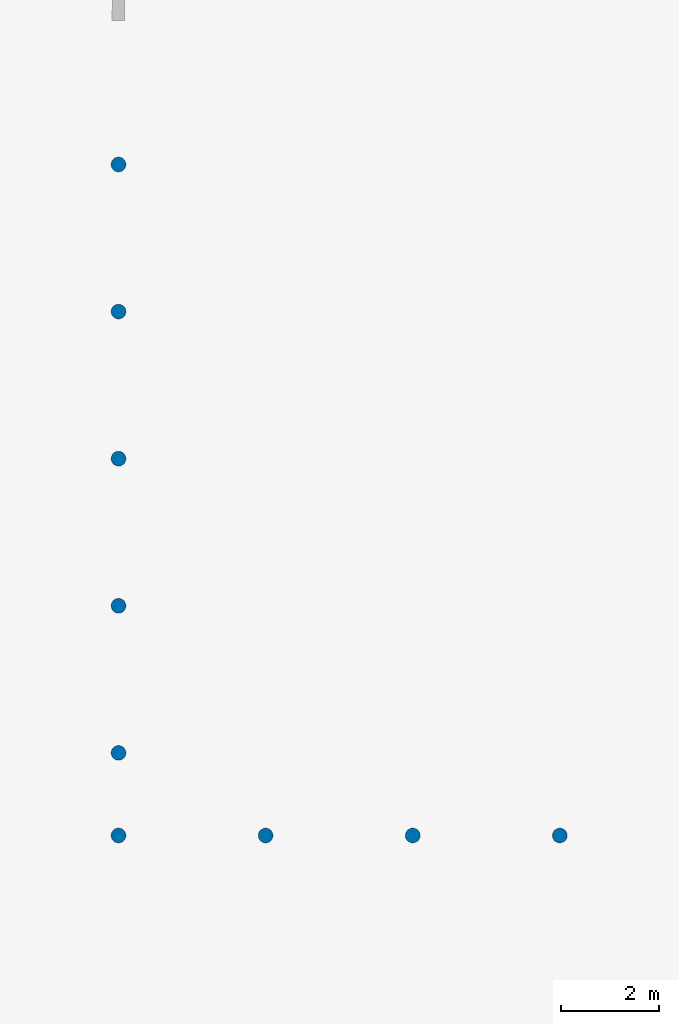
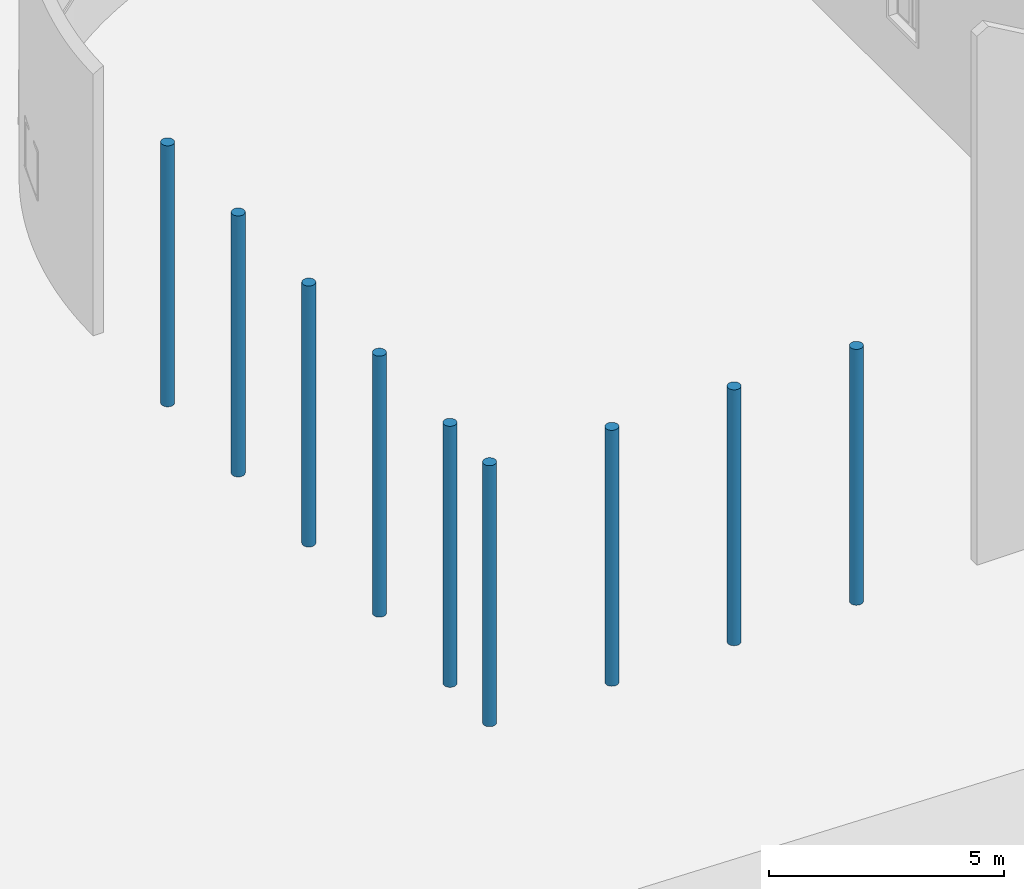
# One storey, part 2 of 39: 9 columns.
"""IFC2X3 building model written with IfcOpenShell, lengths in millimetres."""

from ifc_helpers import new_model, entity, si_unit, converted_unit, derived_unit, direction, frame, frame_2d, origin, origin_2d_with_axis, place, context, subcontext, project, spatial, circle, extrude, source, transform, mapped, material, type_object, type_shapes, element, save


model = new_model("IFC2X3")

# Units and contexts
model_context = context("Model", 3, precision=1e-06, world=origin(), true_north=direction((2.0, 6.12303176911189e-17, 1.0)))
context_of_model = context(None, 3, precision=1e-06, world=origin(), true_north=direction((2.0, 6.12303176911189e-17, 1.0)))
body_context = subcontext(model_context, "Body", "Model", "MODEL_VIEW")
ifc_project = project(units=[si_unit("LENGTHUNIT", "METRE", prefix="MILLI"), si_unit("AREAUNIT", "SQUARE_METRE", prefix="MILLI"), si_unit("VOLUMEUNIT", "CUBIC_METRE", prefix="MILLI"), converted_unit("PLANEANGLEUNIT", "DEGREE", entity("IfcRatioMeasure", 0.0174532925199433), si_unit("PLANEANGLEUNIT", "RADIAN"), dimensions=[0, 0, 0, 0, 0, 0, 0]), si_unit("MASSUNIT", "GRAM", prefix="KILO"), si_unit("TIMEUNIT", "SECOND"), si_unit("THERMODYNAMICTEMPERATUREUNIT", "KELVIN"), derived_unit("THERMALTRANSMITTANCEUNIT", [(si_unit("MASSUNIT", "GRAM", prefix="KILO"), 1), (si_unit("THERMODYNAMICTEMPERATUREUNIT", "KELVIN"), -1), (si_unit("TIMEUNIT", "SECOND"), -3)]), derived_unit("VOLUMETRICFLOWRATEUNIT", [(si_unit("LENGTHUNIT", "METRE"), 3), (si_unit("TIMEUNIT", "SECOND"), -1)])], contexts=[model_context, context_of_model])

# Site, building, storey
site_placement = place(None, origin())
site = spatial("IfcSite", under=ifc_project, at=site_placement, CompositionType="ELEMENT")
building_placement = place(site_placement, origin())
building = spatial("IfcBuilding", under=site, at=building_placement, CompositionType="ELEMENT")
storey_placement = place(building_placement, frame((0.0, 0.0, 4000.0)))
storey = spatial("IfcBuildingStorey", under=building, at=storey_placement, Name="Level 2", CompositionType="ELEMENT", Elevation=4000.0)

# Columns
ifc_material = material(Name="Concrete - Cast-in-Place Concrete")
column_type_1 = type_object("IfcColumnType", Name="300mm", PredefinedType="COLUMN", material=ifc_material)
shared_shape_1 = source(origin(), body_context, "Body", "SweptSolid", [
    extrude(circle(Radius=149.999999999996, at=frame_2d((-337191.196209225, 238337.530060918), x_axis=(1.0, 0.0))), origin(), (0.0, 0.0, 1.0), 6770.79056191359),
])
type_shapes(column_type_1, [shared_shape_1])
column_1_placement = place(storey_placement, frame((0.0, 0.0, 362.0)))
element("IfcColumn", 1, at=column_1_placement, inside=storey, type_object=column_type_1, material=ifc_material, Name="M_Concrete-Round-Column:300mm", ObjectType="300mm", context=body_context, shape_type="MappedRepresentation", body=[
    mapped(shared_shape_1, transform((0.0, 0.0, 0.0), scale=1.0)),
])
column_type_2 = type_object("IfcColumnType", Name="300mm", PredefinedType="COLUMN", material=ifc_material)
shared_shape_2 = source(origin(), body_context, "Body", "SweptSolid", [
    extrude(circle(Radius=149.999999999996, at=frame_2d((-337191.196209225, 235337.530060918), x_axis=(1.0, 0.0))), origin(), (0.0, 0.0, 1.0), 6770.79056191359),
])
type_shapes(column_type_2, [shared_shape_2])
column_2_placement = place(storey_placement, frame((0.0, 0.0, 362.0)))
element("IfcColumn", 2, at=column_2_placement, inside=storey, type_object=column_type_2, material=ifc_material, Name="M_Concrete-Round-Column:300mm", ObjectType="300mm", context=body_context, shape_type="MappedRepresentation", body=[
    mapped(shared_shape_2, transform((0.0, 0.0, 0.0), scale=1.0)),
])
column_type_3 = type_object("IfcColumnType", Name="300mm", PredefinedType="COLUMN", material=ifc_material)
shared_shape_3 = source(origin(), body_context, "Body", "SweptSolid", [
    extrude(circle(Radius=149.999999999996, at=frame_2d((-337191.196209225, 232337.530060918), x_axis=(1.0, 0.0))), origin(), (0.0, 0.0, 1.0), 6770.79056191359),
])
type_shapes(column_type_3, [shared_shape_3])
column_3_placement = place(storey_placement, frame((0.0, 0.0, 362.0)))
element("IfcColumn", 3, at=column_3_placement, inside=storey, type_object=column_type_3, material=ifc_material, Name="M_Concrete-Round-Column:300mm", ObjectType="300mm", context=body_context, shape_type="MappedRepresentation", body=[
    mapped(shared_shape_3, transform((0.0, 0.0, 0.0), scale=1.0)),
])
column_type_4 = type_object("IfcColumnType", Name="300mm", PredefinedType="COLUMN", material=ifc_material)
shared_shape_4 = source(origin(), body_context, "Body", "SweptSolid", [
    extrude(circle(Radius=149.999999999996, at=frame_2d((-337191.196209225, 229337.530060918), x_axis=(1.0, 0.0))), origin(), (0.0, 0.0, 1.0), 6770.79056191359),
])
type_shapes(column_type_4, [shared_shape_4])
column_4_placement = place(storey_placement, frame((0.0, 0.0, 362.0)))
element("IfcColumn", 4, at=column_4_placement, inside=storey, type_object=column_type_4, material=ifc_material, Name="M_Concrete-Round-Column:300mm", ObjectType="300mm", context=body_context, shape_type="MappedRepresentation", body=[
    mapped(shared_shape_4, transform((0.0, 0.0, 0.0), scale=1.0)),
])
column_type_5 = type_object("IfcColumnType", Name="300mm", PredefinedType="COLUMN", material=ifc_material)
shared_shape_5 = source(origin(), body_context, "Body", "SweptSolid", [
    extrude(circle(Radius=149.999999999996, at=frame_2d((-337191.196209225, 226337.530060918), x_axis=(1.0, 0.0))), origin(), (0.0, 0.0, 1.0), 6770.79056191359),
])
type_shapes(column_type_5, [shared_shape_5])
column_5_placement = place(storey_placement, frame((0.0, 0.0, 362.0)))
element("IfcColumn", 5, at=column_5_placement, inside=storey, type_object=column_type_5, material=ifc_material, Name="M_Concrete-Round-Column:300mm", ObjectType="300mm", context=body_context, shape_type="MappedRepresentation", body=[
    mapped(shared_shape_5, transform((0.0, 0.0, 0.0), scale=1.0)),
])
column_type_6 = type_object("IfcColumnType", Name="300mm", PredefinedType="COLUMN", material=ifc_material)
shared_shape_6 = source(origin(), body_context, "Body", "SweptSolid", [
    extrude(circle(Radius=149.999999999996, at=frame_2d((-337191.196209225, 224652.530060918), x_axis=(1.0, 0.0))), origin(), (0.0, 0.0, 1.0), 6770.79056191359),
])
type_shapes(column_type_6, [shared_shape_6])
column_6_placement = place(storey_placement, frame((0.0, 0.0, 362.0)))
element("IfcColumn", 6, at=column_6_placement, inside=storey, type_object=column_type_6, material=ifc_material, Name="M_Concrete-Round-Column:300mm", ObjectType="300mm", context=body_context, shape_type="MappedRepresentation", body=[
    mapped(shared_shape_6, transform((0.0, 0.0, 0.0), scale=1.0)),
])
column_type_7 = type_object("IfcColumnType", Name="300mm", PredefinedType="COLUMN", material=ifc_material)
shared_shape_7 = source(origin(), body_context, "Body", "SweptSolid", [
    extrude(circle(Radius=149.999999999996, at=origin_2d_with_axis()), origin(), (0.0, 0.0, 1.0), 6638.0),
])
type_shapes(column_type_7, [shared_shape_7])
for number, where, name in (
    (7, (-334191.196209225, 224652.530060918, 362.0), "M_Concrete-Round-Column:300mm"),
    (8, (-331191.196209225, 224652.530060918, 362.0), "M_Concrete-Round-Column:300mm"),
    (9, (-328191.196209225, 224652.530060918, 362.0), "M_Concrete-Round-Column:300mm"),
):
    element("IfcColumn", number, at=place(storey_placement, frame(where)), inside=storey, type_object=column_type_7, material=ifc_material, Name=name, ObjectType="300mm", context=body_context, shape_type="MappedRepresentation", body=[
        mapped(shared_shape_7, transform((0.0, 0.0, 0.0), scale=1.0)),
    ])

save(model, "model.ifc")
